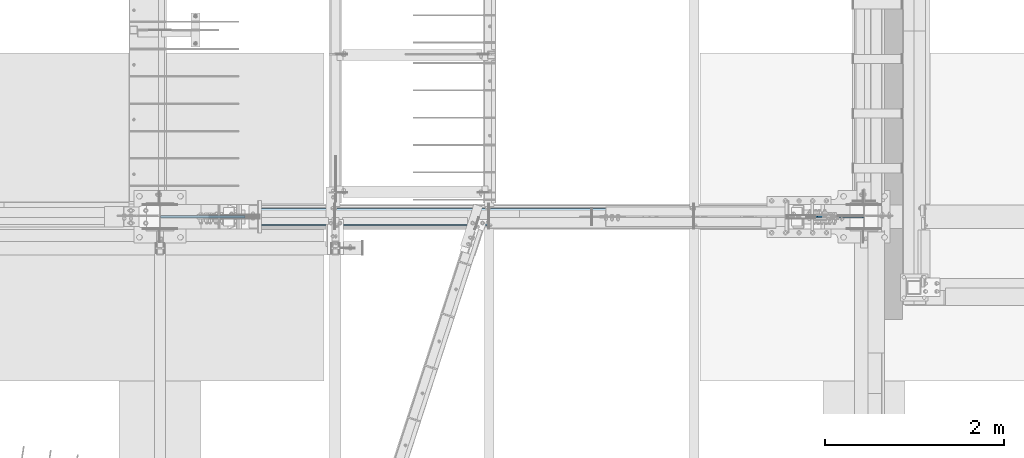
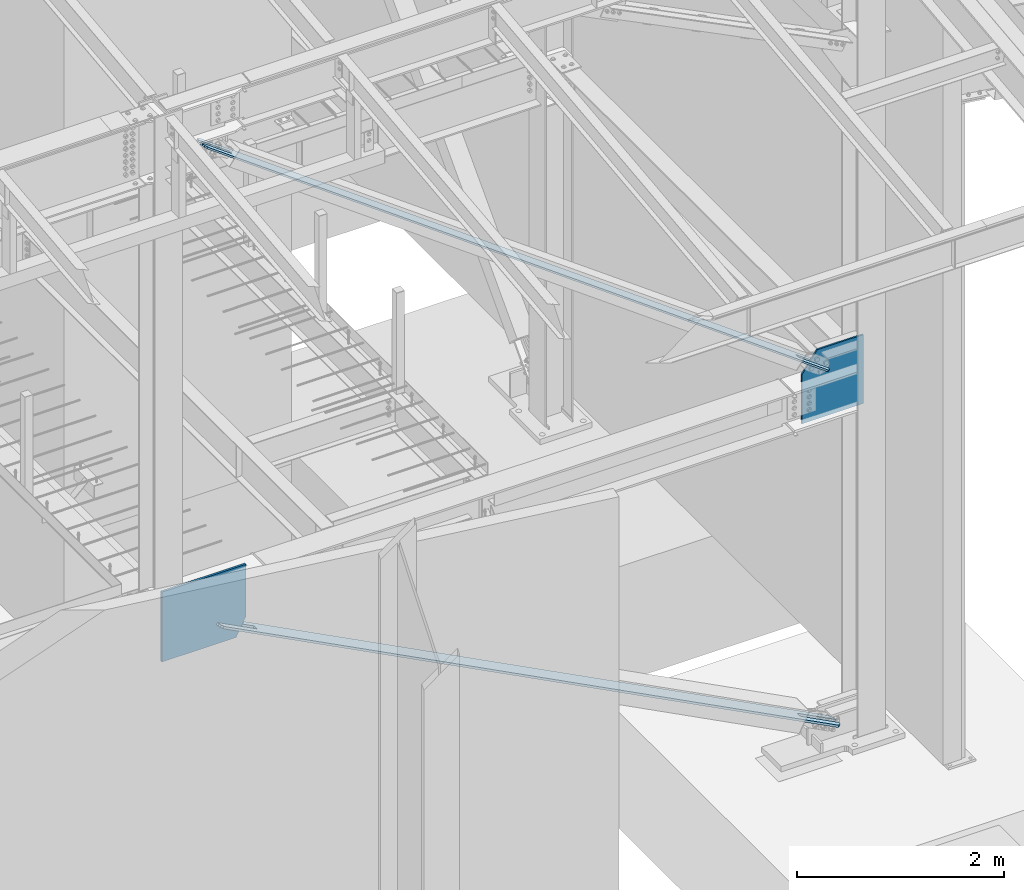
# One storey, part 969 of 1179: 4 plates, 4 elements without a shape of their own.
"""IFC2X3 building model written with IfcOpenShell, lengths in millimetres."""

from ifc_helpers import new_model, si_unit, frame, origin_with_axes, place, context, subcontext, project, spatial, faceted_brep, material, type_object, element, aggregate, save


model = new_model("IFC2X3")

# Units and contexts
model_context = context("Model", 3, precision=1e-05, world=origin_with_axes())
body_context = subcontext(model_context, "Body", "Model", "MODEL_VIEW")
ifc_project = project(units=[si_unit("LENGTHUNIT", "METRE", prefix="MILLI"), si_unit("AREAUNIT", "SQUARE_METRE"), si_unit("VOLUMEUNIT", "CUBIC_METRE"), si_unit("MASSUNIT", "GRAM", prefix="KILO"), si_unit("TIMEUNIT", "SECOND"), si_unit("PLANEANGLEUNIT", "RADIAN"), si_unit("SOLIDANGLEUNIT", "STERADIAN"), si_unit("THERMODYNAMICTEMPERATUREUNIT", "DEGREE_CELSIUS"), si_unit("LUMINOUSINTENSITYUNIT", "LUMEN")], contexts=[model_context])

# Site, building, storey
site_placement = place(None, origin_with_axes())
site = spatial("IfcSite", under=ifc_project, at=site_placement, CompositionType="ELEMENT")
building_placement = place(site_placement, origin_with_axes())
building = spatial("IfcBuilding", under=site, at=building_placement, Name="Undefined", CompositionType="ELEMENT")
storey_placement = place(building_placement, origin_with_axes())
storey = spatial("IfcBuildingStorey", under=building, at=storey_placement, Name="Undefined", CompositionType="ELEMENT", Elevation=0.0)

# Assembly, plate
assembly_1_placement = place(storey_placement, origin_with_axes())
assembly_1 = element("IfcElementAssembly", 1, at=assembly_1_placement, inside=storey, Name="CB", AssemblyPlace="NOTDEFINED", PredefinedType="RIGID_FRAME")
ifc_material_1 = material(Name="STEEL/A36")
plate_type_1 = type_object("IfcPlateType", PredefinedType="NOTDEFINED")
plate_1_placement = place(assembly_1_placement, frame((16891.428258857, 5341.9375, 9278.1090297881), z_axis=(0.807759850958799, 0.0, -0.589511681969932), x_axis=(0.0, 1.0, 0.0)))
plate_1 = element("IfcPlate", 2, at=plate_1_placement, type_object=plate_type_1, material=ifc_material_1, Name="CB", context=body_context, shape_type="Brep", body=[
    faceted_brep([(0.0, -9.52500000000691, 71.4375), (0.0, -9.52500000083819, 8601.27598161249), (0.0, 9.52499999916836, 8601.27598161249), (0.0, 9.52500000000327, 71.4374999999909), (5.4378558962253, -9.52500000084183, 8628.61392931208), (5.4378558962253, 9.52499999916472, 8628.61392931208), (20.923559318986, -9.52500000084183, 8651.78992229352), (20.923559318986, 9.52499999916472, 8651.78992229352), (44.0995523004185, -9.52500000084183, 8667.27562571629), (44.0995523004185, 9.52499999916108, 8667.27562571629), (71.4375, -9.52500000084547, 8672.71348161251), (71.4375, 9.52499999916108, 8672.71348161251), (71.4375, -9.52500000080545, 8253.67174081412), (71.4375, 9.5249999992011, 8253.67174081412), (115.887500000001, -9.52500000080545, 8253.67174081412), (115.887500000001, 9.5249999992011, 8253.67174081412), (115.887500000001, -9.52500000084547, 8672.71348161251), (115.887500000001, 9.52499999916108, 8672.71348161251), (143.225447699582, -9.52500000084183, 8667.27562571629), (143.225447699582, 9.52499999916108, 8667.27562571629), (166.401440681015, -9.52500000084183, 8651.78992229352), (166.401440681015, 9.52499999916472, 8651.78992229352), (181.887144103775, -9.52500000084183, 8628.61392931208), (181.887144103775, 9.52499999916472, 8628.61392931208), (187.325000000001, -9.52500000083819, 8601.27598161249), (187.325000000001, 9.52499999916836, 8601.27598161249), (187.324999999997, -9.52500000000691, 71.4375), (187.324999999997, 9.52500000000327, 71.4374999999909), (181.88714410377, -9.52500000000691, 44.0995523004203), (181.88714410377, 9.52500000000509, 44.0995523004112), (166.401440681009, -9.52500000000691, 20.9235593189915), (166.401440681009, 9.52500000000509, 20.9235593189787), (143.22544769958, -9.52500000000327, 5.43785589623076), (143.22544769958, 9.52500000000509, 5.43785589621621), (115.887499999997, -9.52500000000509, 5.45696821063757e-12), (115.887499999997, 9.52500000000691, -7.27595761418343e-12), (115.887500000001, -9.52500000004511, 419.041740798395), (115.887500000001, 9.52499999996144, 419.041740798397), (71.4375, -9.52500000004511, 419.041740798395), (71.4375, 9.52499999996144, 419.041740798397), (71.4375, -9.52500000000509, 5.45696821063757e-12), (71.4375, 9.52500000000691, -7.27595761418343e-12), (44.0995523004167, -9.52500000000327, 5.43785589623076), (44.0995523004167, 9.52500000000509, 5.43785589621621), (20.9235593189878, -9.52500000000691, 20.9235593189915), (20.9235593189878, 9.52500000000509, 20.9235593189787), (5.43785589622712, -9.52500000000691, 44.0995523004203), (5.43785589622712, 9.52500000000509, 44.0995523004112)], [[[0, 1, 2, 3]], [[1, 4, 5, 2]], [[4, 6, 7, 5]], [[6, 8, 9, 7]], [[8, 10, 11, 9]], [[10, 12, 13, 11]], [[12, 14, 15, 13]], [[14, 16, 17, 15]], [[16, 18, 19, 17]], [[18, 20, 21, 19]], [[20, 22, 23, 21]], [[22, 24, 25, 23]], [[24, 26, 27, 25]], [[26, 28, 29, 27]], [[28, 30, 31, 29]], [[30, 32, 33, 31]], [[32, 34, 35, 33]], [[34, 36, 37, 35]], [[36, 38, 39, 37]], [[38, 40, 41, 39]], [[40, 42, 43, 41]], [[42, 44, 45, 43]], [[44, 46, 47, 45]], [[46, 0, 3, 47]], [[5, 7, 9, 11, 13, 15, 17, 19, 21, 23, 25, 27, 29, 31, 33, 35, 37, 39, 41, 43, 45, 47, 3, 2]], [[46, 44, 42, 40, 38, 36, 34, 32, 30, 28, 26, 24, 22, 20, 18, 16, 14, 12, 10, 8, 6, 4, 1, 0]]]),
])
aggregate(assembly_1, [plate_1])

assembly_2_placement = place(storey_placement, origin_with_axes())
assembly_2 = element("IfcElementAssembly", 3, at=assembly_2_placement, inside=storey, Name="CB", AssemblyPlace="NOTDEFINED", PredefinedType="RIGID_FRAME")
plate_type_2 = type_object("IfcPlateType", PredefinedType="NOTDEFINED")
plate_2_placement = place(assembly_2_placement, frame((24015.2647725602, 5530.85, -63.774581497662), z_axis=(-0.887207986876204, 0.0, 0.461369686935622), x_axis=(0.0, -1.0, 0.0)))
plate_2 = element("IfcPlate", 4, at=plate_2_placement, type_object=plate_type_2, material=ifc_material_1, Name="CB", context=body_context, shape_type="Brep", body=[
    faceted_brep([(0.0, -12.700000000139, 66.6750030518815), (0.0, -12.7000000061216, 7760.10749282274), (0.0, 12.6999999938671, 7760.10749282276), (0.0, 12.6999999998006, 66.6750030519361), (5.0753324021116, -12.7000000061435, 7785.62291184358), (5.0753324021116, 12.6999999938471, 7785.6229118436), (19.528656258226, -12.7000000061616, 7807.25383961634), (19.528656258226, 12.6999999938289, 7807.25383961636), (41.1595840309583, -12.7000000061707, 7821.70716347248), (41.1595840309583, 12.699999993818, 7821.7071634725), (66.6750000000002, -12.7000000061762, 7826.7824958746), (66.6750000000002, 12.6999999938143, 7826.78249587462), (66.6750000000002, -12.7000000057797, 7328.06135702015), (66.6750000000002, 12.6999999942091, 7328.06135702018), (123.825, -12.7000000057797, 7328.06135702015), (123.825, 12.6999999942091, 7328.06135702018), (123.824996948242, -12.7000000061762, 7826.7824958746), (123.824996948242, 12.6999999938143, 7826.78249587462), (149.340415969042, -12.7000000061707, 7821.70716347248), (149.340415969042, 12.699999993818, 7821.7071634725), (170.971343741774, -12.7000000061616, 7807.25383961634), (170.971343741774, 12.6999999938289, 7807.25383961636), (185.424667597888, -12.7000000061435, 7785.62291184358), (185.424667597888, 12.6999999938471, 7785.6229118436), (190.5, -12.7000000061216, 7760.10749282274), (190.5, 12.6999999938671, 7760.10749282276), (190.5, -12.700000000139, 66.6750030518815), (190.5, 12.6999999998006, 66.6750030519361), (185.424667597889, -12.7000000000735, 41.159584031022), (185.424667597889, 12.6999999998661, 41.1595840310729), (170.971343741774, -12.7000000000189, 19.5286562582405), (170.971343741774, 12.6999999999171, 19.5286562582951), (149.340415969042, -12.6999999999825, 5.07533240209159), (149.340415969042, 12.6999999999571, 5.07533240214616), (123.824999618709, -12.7000000000002, 0.0), (123.8249996187, 12.6999999999996, 0.0), (123.825, -12.7000000002045, 498.721138851377), (123.825, 12.6999999997697, 498.721138851402), (66.675, -12.7000000002045, 498.721138851377), (66.675, 12.6999999997697, 498.721138851402), (66.6750030517578, -12.699999999968, -2.91038304567337e-11), (66.6750030517578, 12.699999999968, 2.91038304567337e-11), (41.1595840309583, -12.6999999999825, 5.07533240209159), (41.1595840309583, 12.6999999999571, 5.07533240214616), (19.5286562582261, -12.7000000000189, 19.5286562582405), (19.5286562582261, 12.6999999999171, 19.5286562582951), (5.0753324021112, -12.7000000000735, 41.159584031022), (5.0753324021112, 12.6999999998661, 41.1595840310729)], [[[0, 1, 2, 3]], [[1, 4, 5, 2]], [[4, 6, 7, 5]], [[6, 8, 9, 7]], [[8, 10, 11, 9]], [[10, 12, 13, 11]], [[12, 14, 15, 13]], [[14, 16, 17, 15]], [[16, 18, 19, 17]], [[18, 20, 21, 19]], [[20, 22, 23, 21]], [[22, 24, 25, 23]], [[24, 26, 27, 25]], [[26, 28, 29, 27]], [[28, 30, 31, 29]], [[30, 32, 33, 31]], [[32, 34, 35, 33]], [[34, 36, 37, 35]], [[36, 38, 39, 37]], [[38, 40, 41, 39]], [[40, 42, 43, 41]], [[42, 44, 45, 43]], [[44, 46, 47, 45]], [[46, 0, 3, 47]], [[5, 7, 9, 11, 13, 15, 17, 19, 21, 23, 25, 27, 29, 31, 33, 35, 37, 39, 41, 43, 45, 47, 3, 2]], [[46, 44, 42, 40, 38, 36, 34, 32, 30, 28, 26, 24, 22, 20, 18, 16, 14, 12, 10, 8, 6, 4, 1, 0]]]),
])
aggregate(assembly_2, [plate_2])

assembly_3_placement = place(storey_placement, origin_with_axes())
assembly_3 = element("IfcElementAssembly", 5, at=assembly_3_placement, inside=storey, Name="COLUMN", AssemblyPlace="NOTDEFINED", PredefinedType="RIGID_FRAME")
ifc_material_2 = material(Name="STEEL/A572-GR.50")
plate_type_3 = type_object("IfcPlateType", PredefinedType="NOTDEFINED")
plate_3_placement = place(assembly_3_placement, frame((24301.45, 5435.6, 4417.60220905338), z_axis=(-1.0, 0.0, 0.0), x_axis=(0.0, 0.0, -1.0)))
plate_3 = element("IfcPlate", 6, at=plate_3_placement, type_object=plate_type_3, material=ifc_material_2, Name="PLATE", context=body_context, shape_type="Brep", body=[
    faceted_brep([(813.977209053381, -9.52499999999964, 0.0), (0.0, -9.52499999999964, 0.0), (0.0, 9.52499999999964, 0.0), (813.977209053381, 9.52499999999964, 0.0), (813.977209053381, -9.52499999999964, 688.474521178847), (813.977209053381, 9.52499999999964, 688.474521178847), (238.434985048143, -9.52499999999964, 688.474521178847), (9.09494701772928e-13, -9.52499999999964, 514.462147440088), (9.09494701772928e-13, 9.52499999999964, 514.462147440088), (238.434985048143, 9.52499999999964, 688.474521178847)], [[[0, 1, 2, 3]], [[4, 0, 3, 5]], [[1, 0, 4, 6, 7]], [[2, 1, 7, 8]], [[5, 3, 2, 8, 9]], [[4, 5, 9, 6]], [[8, 7, 6, 9]]]),
])
aggregate(assembly_3, [plate_3])

assembly_4_placement = place(storey_placement, origin_with_axes())
assembly_4 = element("IfcElementAssembly", 7, at=assembly_4_placement, inside=storey, Name="COLUMN", AssemblyPlace="NOTDEFINED", PredefinedType="RIGID_FRAME")
plate_type_4 = type_object("IfcPlateType", PredefinedType="NOTDEFINED")
plate_4_placement = place(assembly_4_placement, frame((17406.035110306, 5435.6, 4121.15), z_axis=(0.0, 0.0, -1.0), x_axis=(-1.0, 0.0, 0.0)))
plate_4 = element("IfcPlate", 8, at=plate_4_placement, type_object=plate_type_4, material=ifc_material_2, Name="PLATE", context=body_context, shape_type="Brep", body=[
    faceted_brep([(0.0, -12.7, 0.0), (0.0, -12.6999999999998, 611.976335934159), (0.0, 12.6999999999998, 611.976335934159), (0.0, 12.7, 0.0), (111.328505457564, -12.6999999999998, 826.059623167386), (111.328505457564, 12.6999999999998, 826.059623167386), (940.485110305955, -12.6999999999998, 826.059623167386), (940.485110305955, 12.6999999999998, 826.059623167386), (940.485110305955, -12.6999999999998, 0.0), (940.485110305955, 12.6999999999998, 0.0)], [[[0, 1, 2, 3]], [[1, 4, 5, 2]], [[4, 6, 7, 5]], [[6, 8, 9, 7]], [[8, 0, 3, 9]], [[5, 7, 9, 3, 2]], [[8, 6, 4, 1, 0]]]),
])
aggregate(assembly_4, [plate_4])

save(model, "model.ifc")
